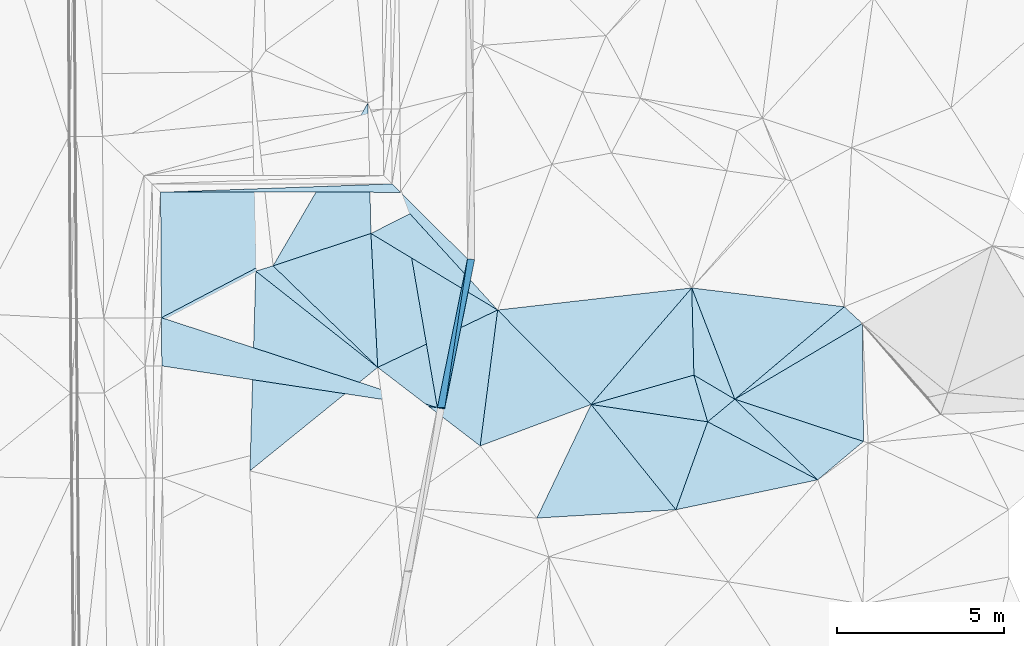
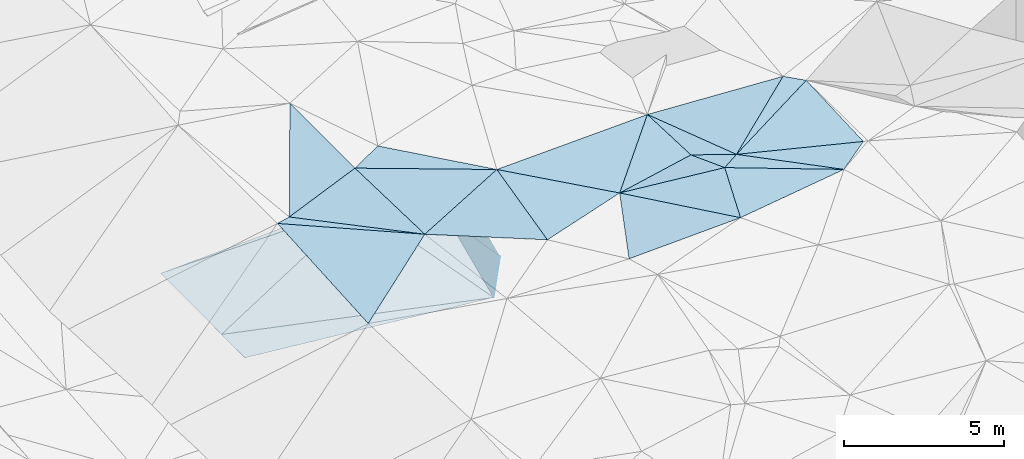
# One storey, part 98 of 275: 29 plates.
"""IFC2X3 building model written with IfcOpenShell, lengths in millimetres."""

from ifc_helpers import new_model, si_unit, frame, origin_with_axes, place, context, subcontext, project, spatial, polyline, outline, extrude, material, type_object, element, save


model = new_model("IFC2X3")

# Units and contexts
model_context = context("Model", 3, precision=1e-05, world=origin_with_axes())
body_context = subcontext(model_context, "Body", "Model", "MODEL_VIEW")
ifc_project = project(units=[si_unit("LENGTHUNIT", "METRE", prefix="MILLI"), si_unit("AREAUNIT", "SQUARE_METRE"), si_unit("VOLUMEUNIT", "CUBIC_METRE"), si_unit("MASSUNIT", "GRAM", prefix="KILO"), si_unit("TIMEUNIT", "SECOND"), si_unit("PLANEANGLEUNIT", "RADIAN"), si_unit("SOLIDANGLEUNIT", "STERADIAN"), si_unit("THERMODYNAMICTEMPERATUREUNIT", "DEGREE_CELSIUS"), si_unit("LUMINOUSINTENSITYUNIT", "LUMEN")], contexts=[model_context])

# Site, building, storey
site_placement = place(None, origin_with_axes())
site = spatial("IfcSite", under=ifc_project, at=site_placement, CompositionType="ELEMENT")
building_placement = place(site_placement, origin_with_axes())
building = spatial("IfcBuilding", under=site, at=building_placement, Name="Undefined", CompositionType="ELEMENT")
storey_placement = place(building_placement, origin_with_axes())
storey = spatial("IfcBuildingStorey", under=building, at=storey_placement, Name="Undefined", CompositionType="ELEMENT", Elevation=0.0)

# Plates
ifc_material = material()
plate_type_1 = type_object("IfcPlateType", PredefinedType="NOTDEFINED")
plate_1_placement = place(storey_placement, frame((-46443.3249652115, 38495.5309227865, 42288.5656825037), z_axis=(0.969840713207776, -0.196187816631066, -0.144635167266357), x_axis=(0.198351134100838, 0.980130872499006, 0.000548065004830517)))
element("IfcPlate", 1, at=plate_1_placement, inside=storey, type_object=plate_type_1, material=ifc_material, Name="00_PR", context=body_context, shape_type="SweptSolid", body=[
    extrude(outline(polyline([(0.0, 0.0), (4561.50439453125, 9.63336788117886e-09), (55.8651733398438, 1515.94470214844), (0.0, 0.0)])), frame((-8.85201319254618e-08, 2.18876761149539e-07, -0.5000001331573), z_axis=(0.0, 0.0, 1.0), x_axis=(1.0, 0.0, 0.0)), (0.0, 0.0, 1.0), 1.0),
])
plate_type_2 = type_object("IfcPlateType", PredefinedType="NOTDEFINED")
plate_2_placement = place(storey_placement, frame((-45538.5450716958, 42966.402624655, 42291.0672994869), z_axis=(0.970515732774917, -0.195204797535353, -0.141401200332771), x_axis=(0.141470671044845, -0.0136585480095269, 0.989848217304245)))
element("IfcPlate", 2, at=plate_2_placement, inside=storey, type_object=plate_type_2, material=ifc_material, Name="00_PR", context=body_context, shape_type="SweptSolid", body=[
    extrude(outline(polyline([(0.0, 0.0), (1515.791015625, 2.63025867752731e-09), (1447.20227050781, 4528.18701171875), (0.0, 0.0)])), frame((-8.85201319254618e-08, 2.18876761149539e-07, -0.5000001331573), z_axis=(0.0, 0.0, 1.0), x_axis=(1.0, 0.0, 0.0)), (0.0, 0.0, 1.0), 1.0),
])
plate_type_3 = type_object("IfcPlateType", PredefinedType="NOTDEFINED")
plate_3_placement = place(storey_placement, frame((-46217.5177496207, 38505.9380985672, 43788.6030210597), z_axis=(0.943574445831135, -0.300132521384731, -0.139956188793887), x_axis=(-0.303203710836228, -0.952925539542481, -0.000652551003531993)))
element("IfcPlate", 3, at=plate_3_placement, inside=storey, type_object=plate_type_3, material=ifc_material, Name="00_PR", context=body_context, shape_type="SweptSolid", body=[
    extrude(outline(polyline([(0.0, 0.0), (45.973445892334, 8.00355337560177e-11), (79.4152069091797, 1514.8935546875), (0.0, 0.0)])), frame((-8.85201319254618e-08, 2.18876761149539e-07, -0.5000001331573), z_axis=(0.0, 0.0, 1.0), x_axis=(1.0, 0.0, 0.0)), (0.0, 0.0, 1.0), 1.0),
])
plate_type_4 = type_object("IfcPlateType", PredefinedType="NOTDEFINED")
plate_4_placement = place(storey_placement, frame((-47805.2381198902, 45216.661314004, 42303.1390161374), z_axis=(0.0125132449151015, 0.0624980377927703, -0.997966639709839), x_axis=(0.70918056043067, -0.704147372423758, -0.0352052640376207)))
element("IfcPlate", 4, at=plate_4_placement, inside=storey, type_object=plate_type_4, material=ifc_material, Name="00_PR", context=body_context, shape_type="SweptSolid", body=[
    extrude(outline(polyline([(0.0, 0.0), (355.060546875, 4.29736246587709e-10), (-4748.9951171875, 5080.736328125), (0.0, 0.0)])), frame((-8.85201319254618e-08, 2.18876761149539e-07, -0.5000001331573), z_axis=(0.0, 0.0, 1.0), x_axis=(1.0, 0.0, 0.0)), (0.0, 0.0, 1.0), 1.0),
])
plate_type_5 = type_object("IfcPlateType", PredefinedType="NOTDEFINED")
plate_5_placement = place(storey_placement, frame((-47553.4421116464, 44966.6153507536, 42290.6379995504), z_axis=(0.000462311416255581, 0.000465616109218789, -0.999999784734874), x_axis=(0.709620532051075, -0.704584062047637, -1.64116230332643e-11)))
element("IfcPlate", 5, at=plate_5_placement, inside=storey, type_object=plate_type_5, material=ifc_material, Name="00_PR", context=body_context, shape_type="SweptSolid", body=[
    extrude(outline(polyline([(0.0, 0.0), (2838.71728515625, 2.50656739808619e-09), (5346.771484375, 3810.11596679688), (0.0, 0.0)])), frame((-8.85201319254618e-08, 2.18876761149539e-07, -0.5000001331573), z_axis=(0.0, 0.0, 1.0), x_axis=(1.0, 0.0, 0.0)), (0.0, 0.0, 1.0), 1.0),
])
plate_type_6 = type_object("IfcPlateType", PredefinedType="NOTDEFINED")
plate_6_placement = place(storey_placement, frame((-47553.4360761631, 44966.6239044874, 42290.6381159669), z_axis=(0.0125332392544365, 0.0175735609341852, -0.999767016794355), x_axis=(-0.885236869123472, -0.464741311066602, -0.019266534005089)))
element("IfcPlate", 6, at=plate_6_placement, inside=storey, type_object=plate_type_6, material=ifc_material, Name="00_PR", context=body_context, shape_type="SweptSolid", body=[
    extrude(outline(polyline([(0.0, 0.0), (8104.2080078125, 1.51194399222732e-08), (6376.30517578125, 3347.83520507813), (0.0, 0.0)])), frame((-8.85201319254618e-08, 2.18876761149539e-07, -0.5000001331573), z_axis=(0.0, 0.0, 1.0), x_axis=(1.0, 0.0, 0.0)), (0.0, 0.0, 1.0), 1.0),
])
plate_type_7 = type_object("IfcPlateType", PredefinedType="NOTDEFINED")
plate_7_placement = place(storey_placement, frame((-47553.4324587626, 44966.6170066779, 42290.6381003164), z_axis=(0.0197766883273106, 0.00377753068347806, -0.999797285883864), x_axis=(0.169011233083725, -0.985614051288112, -0.000380782030189369)))
element("IfcPlate", 7, at=plate_7_placement, inside=storey, type_object=plate_type_7, material=ifc_material, Name="00_PR", context=body_context, shape_type="SweptSolid", body=[
    extrude(outline(polyline([(0.0, 0.0), (6565.43603515625, 3.58704710379243e-09), (2499.72631835938, 7709.05712890625), (0.0, 0.0)])), frame((-8.85201319254618e-08, 2.18876761149539e-07, -0.5000001331573), z_axis=(0.0, 0.0, 1.0), x_axis=(1.0, 0.0, 0.0)), (0.0, 0.0, 1.0), 1.0),
])
plate_type_8 = type_object("IfcPlateType", PredefinedType="NOTDEFINED")
plate_8_placement = place(storey_placement, frame((-46443.79837359, 38495.6358911263, 42288.1381792545), z_axis=(0.0230331485194836, 0.0137604097820277, -0.999639997795161), x_axis=(-0.988457050788574, 0.15007921894718, -0.0207095819986449)))
element("IfcPlate", 8, at=plate_8_placement, inside=storey, type_object=plate_type_8, material=ifc_material, Name="00_PR", context=body_context, shape_type="SweptSolid", body=[
    extrude(outline(polyline([(0.0, 0.0), (8369.990234375, 2.26027623284608e-08), (8597.2470703125, 1430.69885253906), (0.0, 0.0)])), frame((-8.85201319254618e-08, 2.18876761149539e-07, -0.5000001331573), z_axis=(0.0, 0.0, 1.0), x_axis=(1.0, 0.0, 0.0)), (0.0, 0.0, 1.0), 1.0),
])
plate_type_9 = type_object("IfcPlateType", PredefinedType="NOTDEFINED")
plate_9_placement = place(storey_placement, frame((-38327.7698010911, 38073.6418527784, 44669.5005537609), z_axis=(-0.0464963739191827, 0.00922264050459556, -0.998875883237998), x_axis=(0.883850083440965, -0.465557927526802, -0.0454405778830896)))
element("IfcPlate", 9, at=plate_9_placement, inside=storey, type_object=plate_type_9, material=ifc_material, Name="00", context=body_context, shape_type="SweptSolid", body=[
    extrude(outline(polyline([(0.0, 0.0), (3741.14965820313, -4.94037522003055e-09), (385.897430419922, 2781.36352539063), (0.0, 0.0)])), frame((-8.85201319254618e-08, 2.18876761149539e-07, -0.5000001331573), z_axis=(0.0, 0.0, 1.0), x_axis=(1.0, 0.0, 0.0)), (0.0, 0.0, 1.0), 1.0),
])
plate_type_10 = type_object("IfcPlateType", PredefinedType="NOTDEFINED")
plate_10_placement = place(storey_placement, frame((-38327.7497224403, 38073.558876709, 44669.5061811373), z_axis=(-0.00633984785099305, -0.156729238662104, -0.987621259429759), x_axis=(-0.989009212063355, 0.146877983389965, -0.0169598481455264)))
element("IfcPlate", 10, at=plate_10_placement, inside=storey, type_object=plate_type_10, material=ifc_material, Name="00", context=body_context, shape_type="SweptSolid", body=[
    extrude(outline(polyline([(0.0, 0.0), (3537.767578125, 1.1303200153634e-08), (617.790710449219, 1343.62744140625), (0.0, 0.0)])), frame((-8.85201319254618e-08, 2.18876761149539e-07, -0.5000001331573), z_axis=(0.0, 0.0, 1.0), x_axis=(1.0, 0.0, 0.0)), (0.0, 0.0, 1.0), 1.0),
])
plate_type_11 = type_object("IfcPlateType", PredefinedType="NOTDEFINED")
plate_11_placement = place(storey_placement, frame((-38740.3098670622, 39476.5541132038, 44449.509605155), z_axis=(-0.0809224906251703, -0.177584731849082, -0.980772763449877), x_axis=(0.860856875791183, -0.508412495767239, 0.0210279231207222)))
element("IfcPlate", 11, at=plate_11_placement, inside=storey, type_object=plate_type_11, material=ifc_material, Name="00", context=body_context, shape_type="SweptSolid", body=[
    extrude(outline(polyline([(0.0, 0.0), (1426.67443847656, 3.96721588913351e-09), (1073.05493164063, 1017.62133789063), (0.0, 0.0)])), frame((-8.85201319254618e-08, 2.18876761149539e-07, -0.5000001331573), z_axis=(0.0, 0.0, 1.0), x_axis=(1.0, 0.0, 0.0)), (0.0, 0.0, 1.0), 1.0),
])
plate_type_12 = type_object("IfcPlateType", PredefinedType="NOTDEFINED")
plate_12_placement = place(storey_placement, frame((-35021.191156916, 36331.8496153809, 44499.507978629), z_axis=(-0.119900735041936, -0.131582992852536, -0.984027301312506), x_axis=(-0.88385008344028, 0.465557927528441, 0.0454405778796064)))
element("IfcPlate", 12, at=plate_12_placement, inside=storey, type_object=plate_type_12, material=ifc_material, Name="00", context=body_context, shape_type="SweptSolid", body=[
    extrude(outline(polyline([(0.0, 0.0), (3741.14965820313, -4.94037522003055e-09), (3327.10571289063, 994.569091796875), (0.0, 0.0)])), frame((-8.85201319254618e-08, 2.18876761149539e-07, -0.5000001331573), z_axis=(0.0, 0.0, 1.0), x_axis=(1.0, 0.0, 0.0)), (0.0, 0.0, 1.0), 1.0),
])
plate_type_13 = type_object("IfcPlateType", PredefinedType="NOTDEFINED")
plate_13_placement = place(storey_placement, frame((-34224.0392858306, 41527.9494436343, 44629.5010315579), z_axis=(-0.0084238428115779, 0.0638858937482698, -0.99792165596918), x_axis=(0.7312668597811, -0.680276673892268, -0.0497235029333329)))
element("IfcPlate", 13, at=plate_13_placement, inside=storey, type_object=plate_type_13, material=ifc_material, Name="00", context=body_context, shape_type="SweptSolid", body=[
    extrude(outline(polyline([(0.0, 0.0), (744.114929199219, -6.12999428994954e-10), (-508.133880615234, 4276.13134765625), (0.0, 0.0)])), frame((-8.85201319254618e-08, 2.18876761149539e-07, -0.5000001331573), z_axis=(0.0, 0.0, 1.0), x_axis=(1.0, 0.0, 0.0)), (0.0, 0.0, 1.0), 1.0),
])
plate_type_14 = type_object("IfcPlateType", PredefinedType="NOTDEFINED")
plate_14_placement = place(storey_placement, frame((-37512.096791345, 38751.300212871, 44479.5001063957), z_axis=(0.0202011318964678, -0.00714540240733253, -0.999770402389738), x_axis=(-0.860856875791868, 0.508412495765947, -0.0210279231239147)))
element("IfcPlate", 14, at=plate_14_placement, inside=storey, type_object=plate_type_14, material=ifc_material, Name="00", context=body_context, shape_type="SweptSolid", body=[
    extrude(outline(polyline([(0.0, 0.0), (1426.67443847656, 3.96721588913351e-09), (2812.97534179688, 2221.47924804688), (0.0, 0.0)])), frame((-8.85201319254618e-08, 2.18876761149539e-07, -0.5000001331573), z_axis=(0.0, 0.0, 1.0), x_axis=(1.0, 0.0, 0.0)), (0.0, 0.0, 1.0), 1.0),
])
plate_type_15 = type_object("IfcPlateType", PredefinedType="NOTDEFINED")
plate_15_placement = place(storey_placement, frame((-48234.355661912, 39707.4559399207, 44599.501549566), z_axis=(-0.0383794440209181, -0.0689440554626503, -0.996882006805724), x_axis=(-0.784720648838485, 0.619720519874399, -0.0126483411209417)))
element("IfcPlate", 15, at=plate_15_placement, inside=storey, type_object=plate_type_15, material=ifc_material, Name="00", context=body_context, shape_type="SweptSolid", body=[
    extrude(outline(polyline([(0.0, 0.0), (4664.6435546875, -1.22736310004257e-09), (4356.66943359375, 448.029174804688), (0.0, 0.0)])), frame((-8.85201319254618e-08, 2.18876761149539e-07, -0.5000001331573), z_axis=(0.0, 0.0, 1.0), x_axis=(1.0, 0.0, 0.0)), (0.0, 0.0, 1.0), 1.0),
])
plate_type_16 = type_object("IfcPlateType", PredefinedType="NOTDEFINED")
plate_16_placement = place(storey_placement, frame((-44633.5560007087, 41430.6037228614, 44769.5012291383), z_axis=(0.0382693570372274, 0.059007012193705, -0.997523748501222), x_axis=(-0.855932468270024, 0.517082727458257, -0.00225005011366355)))
element("IfcPlate", 16, at=plate_16_placement, inside=storey, type_object=plate_type_16, material=ifc_material, Name="00", context=body_context, shape_type="SweptSolid", body=[
    extrude(outline(polyline([(0.0, 0.0), (4444.3447265625, 3.87444742955267e-09), (3749.86669921875, 1115.84057617188), (0.0, 0.0)])), frame((-8.85201319254618e-08, 2.18876761149539e-07, -0.5000001331573), z_axis=(0.0, 0.0, 1.0), x_axis=(1.0, 0.0, 0.0)), (0.0, 0.0, 1.0), 1.0),
])
plate_type_17 = type_object("IfcPlateType", PredefinedType="NOTDEFINED")
plate_17_placement = place(storey_placement, frame((-37512.0850019845, 38751.3047892875, 44479.5004782918), z_axis=(0.0438738556728733, 0.00201499777990929, -0.999035046718754), x_axis=(-0.360471225394347, 0.932666022655788, -0.0139494030743952)))
element("IfcPlate", 17, at=plate_17_placement, inside=storey, type_object=plate_type_17, material=ifc_material, Name="00", context=body_context, shape_type="SweptSolid", body=[
    extrude(outline(polyline([(0.0, 0.0), (3584.3828125, 4.76575223729014e-09), (1402.30554199219, 4071.49096679688), (0.0, 0.0)])), frame((-8.85201319254618e-08, 2.18876761149539e-07, -0.5000001331573), z_axis=(0.0, 0.0, 1.0), x_axis=(1.0, 0.0, 0.0)), (0.0, 0.0, 1.0), 1.0),
])
plate_type_18 = type_object("IfcPlateType", PredefinedType="NOTDEFINED")
plate_18_placement = place(storey_placement, frame((-48529.4109261827, 47646.0800810492, 44899.5016543625), z_axis=(0.0724682144374577, 0.0373175848286961, -0.996672341222932), x_axis=(0.0234159136017387, -0.999087991785315, -0.0357054570140624)))
element("IfcPlate", 18, at=plate_18_placement, inside=storey, type_object=plate_type_18, material=ifc_material, Name="00", context=body_context, shape_type="SweptSolid", body=[
    extrude(outline(polyline([(0.0, 0.0), (3920.96923828125, -3.01952240988612e-09), (4831.20361328125, 2968.22729492188), (0.0, 0.0)])), frame((-8.85201319254618e-08, 2.18876761149539e-07, -0.5000001331573), z_axis=(0.0, 0.0, 1.0), x_axis=(1.0, 0.0, 0.0)), (0.0, 0.0, 1.0), 1.0),
])
plate_type_19 = type_object("IfcPlateType", PredefinedType="NOTDEFINED")
plate_19_placement = place(storey_placement, frame((-33650.1982904522, 37484.6656650759, 44389.5009682183), z_axis=(-0.0392028237490612, -0.048613212888309, -0.998048042001374), x_axis=(-0.763942657938631, -0.642366277741605, 0.0612958449004167)))
element("IfcPlate", 19, at=plate_19_placement, inside=storey, type_object=plate_type_19, material=ifc_material, Name="00", context=body_context, shape_type="SweptSolid", body=[
    extrude(outline(polyline([(0.0, 0.0), (1794.5751953125, 1.86264514923096e-09), (2142.17822265625, 3455.13696289063), (0.0, 0.0)])), frame((-8.85201319254618e-08, 2.18876761149539e-07, -0.5000001331573), z_axis=(0.0, 0.0, 1.0), x_axis=(1.0, 0.0, 0.0)), (0.0, 0.0, 1.0), 1.0),
])
plate_type_20 = type_object("IfcPlateType", PredefinedType="NOTDEFINED")
plate_20_placement = place(storey_placement, frame((-48437.6203458688, 43728.6886747637, 44759.5006023156), z_axis=(0.0274725913656442, 0.041129563262152, -0.998776058858802), x_axis=(0.855932468269246, -0.517082727459538, 0.0022500501154411)))
element("IfcPlate", 20, at=plate_20_placement, inside=storey, type_object=plate_type_20, material=ifc_material, Name="00", context=body_context, shape_type="SweptSolid", body=[
    extrude(outline(polyline([(0.0, 0.0), (4444.3447265625, 3.87444742955267e-09), (2252.9306640625, 3340.82373046875), (0.0, 0.0)])), frame((-8.85201319254618e-08, 2.18876761149539e-07, -0.5000001331573), z_axis=(0.0, 0.0, 1.0), x_axis=(1.0, 0.0, 0.0)), (0.0, 0.0, 1.0), 1.0),
])
plate_type_21 = type_object("IfcPlateType", PredefinedType="NOTDEFINED")
plate_21_placement = place(storey_placement, frame((-44633.5970461584, 41430.5807089734, 44769.500513223), z_axis=(-0.0438214543343565, 0.0129800267047143, -0.998955053566859), x_axis=(0.702727049832824, -0.710331028976299, -0.040056493939532)))
element("IfcPlate", 21, at=plate_21_placement, inside=storey, type_object=plate_type_21, material=ifc_material, Name="00", context=body_context, shape_type="SweptSolid", body=[
    extrude(outline(polyline([(0.0, 0.0), (3994.35864257813, -1.68893166119233e-09), (2531.01977539063, 3243.78466796875), (0.0, 0.0)])), frame((-8.85201319254618e-08, 2.18876761149539e-07, -0.5000001331573), z_axis=(0.0, 0.0, 1.0), x_axis=(1.0, 0.0, 0.0)), (0.0, 0.0, 1.0), 1.0),
])
plate_type_22 = type_object("IfcPlateType", PredefinedType="NOTDEFINED")
plate_22_placement = place(storey_placement, frame((-37512.1091358686, 38751.3324157214, 44479.5008172531), z_axis=(-0.00448597971495295, 0.0572604647827299, -0.998349195000859), x_axis=(0.860067444710566, 0.509549631547064, 0.0253606691411904)))
element("IfcPlate", 22, at=plate_22_placement, inside=storey, type_object=plate_type_22, material=ifc_material, Name="00", context=body_context, shape_type="SweptSolid", body=[
    extrude(outline(polyline([(0.0, 0.0), (4455.71826171875, 1.50685082189739e-08), (2673.83374023438, 3062.27270507813), (0.0, 0.0)])), frame((-8.85201319254618e-08, 2.18876761149539e-07, -0.5000001331573), z_axis=(0.0, 0.0, 1.0), x_axis=(1.0, 0.0, 0.0)), (0.0, 0.0, 1.0), 1.0),
])
plate_type_23 = type_object("IfcPlateType", PredefinedType="NOTDEFINED")
plate_23_placement = place(storey_placement, frame((-48234.3012172829, 39707.5120206487, 44599.5017032268), z_axis=(0.0705100820953868, 0.0432177951472997, -0.996574407912178), x_axis=(-0.717316118285598, 0.696444757419317, -0.020549606099164)))
element("IfcPlate", 23, at=plate_23_placement, inside=storey, type_object=plate_type_23, material=ifc_material, Name="00", context=body_context, shape_type="SweptSolid", body=[
    extrude(outline(polyline([(0.0, 0.0), (4379.64599609375, 1.83308657142334e-08), (2943.06884765625, 2752.29833984375), (0.0, 0.0)])), frame((-8.85201319254618e-08, 2.18876761149539e-07, -0.5000001331573), z_axis=(0.0, 0.0, 1.0), x_axis=(1.0, 0.0, 0.0)), (0.0, 0.0, 1.0), 1.0),
])
plate_type_24 = type_object("IfcPlateType", PredefinedType="NOTDEFINED")
plate_24_placement = place(storey_placement, frame((-45158.3756742461, 37349.9058393298, 44739.5005324397), z_axis=(0.0465092882201021, 0.00136211160849913, -0.998916928859065), x_axis=(-0.793167928752642, 0.607932048800836, -0.0361007041352641)))
element("IfcPlate", 24, at=plate_24_placement, inside=storey, type_object=plate_type_24, material=ifc_material, Name="00", context=body_context, shape_type="SweptSolid", body=[
    extrude(outline(polyline([(0.0, 0.0), (3878.04077148438, -3.43788997270167e-10), (2063.4130859375, 3559.568359375), (0.0, 0.0)])), frame((-8.85201319254618e-08, 2.18876761149539e-07, -0.5000001331573), z_axis=(0.0, 0.0, 1.0), x_axis=(1.0, 0.0, 0.0)), (0.0, 0.0, 1.0), 1.0),
])
plate_type_25 = type_object("IfcPlateType", PredefinedType="NOTDEFINED")
plate_25_placement = place(storey_placement, frame((-39281.2593404788, 35432.5516009752, 44689.5000922955), z_axis=(0.0152052207329369, -0.0130607485416221, -0.999799088872357), x_axis=(-0.627094948541379, 0.778693434683762, -0.0197093960914919)))
element("IfcPlate", 25, at=plate_25_placement, inside=storey, type_object=plate_type_25, material=ifc_material, Name="00", context=body_context, shape_type="SweptSolid", body=[
    extrude(outline(polyline([(0.0, 0.0), (4058.97778320313, -2.9431248549372e-09), (1459.03735351563, 2399.189453125), (0.0, 0.0)])), frame((-8.85201319254618e-08, 2.18876761149539e-07, -0.5000001331573), z_axis=(0.0, 0.0, 1.0), x_axis=(1.0, 0.0, 0.0)), (0.0, 0.0, 1.0), 1.0),
])
plate_type_26 = type_object("IfcPlateType", PredefinedType="NOTDEFINED")
plate_26_placement = place(storey_placement, frame((-41826.6352027982, 38593.2416752527, 44609.5002541337), z_axis=(-0.00769123907239546, -0.0314914361461269, -0.999474429033072), x_axis=(0.627094948545061, -0.778693434680792, 0.0197093960916683)))
element("IfcPlate", 26, at=plate_26_placement, inside=storey, type_object=plate_type_26, material=ifc_material, Name="00", context=body_context, shape_type="SweptSolid", body=[
    extrude(outline(polyline([(0.0, 0.0), (4058.97778320313, -2.9431248549372e-09), (1635.70739746094, 3409.8916015625), (0.0, 0.0)])), frame((-8.85201319254618e-08, 2.18876761149539e-07, -0.5000001331573), z_axis=(0.0, 0.0, 1.0), x_axis=(1.0, 0.0, 0.0)), (0.0, 0.0, 1.0), 1.0),
])
plate_type_27 = type_object("IfcPlateType", PredefinedType="NOTDEFINED")
plate_27_placement = place(storey_placement, frame((-52072.1391362882, 36601.4704741924, 44411.500356581), z_axis=(0.0323271686059049, 0.0205394783714789, -0.99926627282129), x_axis=(0.0295587913776613, 0.999331853491677, 0.0214970800152447)))
element("IfcPlate", 27, at=plate_27_placement, inside=storey, type_object=plate_type_27, material=ifc_material, Name="00", context=body_context, shape_type="SweptSolid", body=[
    extrude(outline(polyline([(0.0, 0.0), (6000.81494140625, 1.52358552441001e-08), (3221.43774414063, 3746.19287109375), (0.0, 0.0)])), frame((-8.85201319254618e-08, 2.18876761149539e-07, -0.5000001331573), z_axis=(0.0, 0.0, 1.0), x_axis=(1.0, 0.0, 0.0)), (0.0, 0.0, 1.0), 1.0),
])
plate_type_28 = type_object("IfcPlateType", PredefinedType="NOTDEFINED")
plate_28_placement = place(storey_placement, frame((-41826.6604482917, 38593.2568292568, 44609.5008408341), z_axis=(-0.0580927180274788, -0.00117481268560498, -0.998310500759826), x_axis=(-0.702727049801293, 0.710331029011612, 0.0400564938664784)))
element("IfcPlate", 28, at=plate_28_placement, inside=storey, type_object=plate_type_28, material=ifc_material, Name="00", context=body_context, shape_type="SweptSolid", body=[
    extrude(outline(polyline([(0.0, 0.0), (3994.35864257813, -1.68893166119233e-09), (355.751739501953, 4615.044921875), (0.0, 0.0)])), frame((-8.85201319254618e-08, 2.18876761149539e-07, -0.5000001331573), z_axis=(0.0, 0.0, 1.0), x_axis=(1.0, 0.0, 0.0)), (0.0, 0.0, 1.0), 1.0),
])
plate_type_29 = type_object("IfcPlateType", PredefinedType="NOTDEFINED")
plate_29_placement = place(storey_placement, frame((-38804.1984186803, 42094.3314077003, 44429.500623126), z_axis=(-0.0492478383867065, -0.0088330074670378, -0.998747529855931), x_axis=(0.0244044845531521, -0.999672988974458, 0.00763781700278473)))
element("IfcPlate", 29, at=plate_29_placement, inside=storey, type_object=plate_type_29, material=ifc_material, Name="00", context=body_context, shape_type="SweptSolid", body=[
    extrude(outline(polyline([(0.0, 0.0), (2618.54931640625, -3.30328475683928e-09), (3427.546875, 3110.80737304688), (0.0, 0.0)])), frame((-8.85201319254618e-08, 2.18876761149539e-07, -0.5000001331573), z_axis=(0.0, 0.0, 1.0), x_axis=(1.0, 0.0, 0.0)), (0.0, 0.0, 1.0), 1.0),
])

save(model, "model.ifc")
